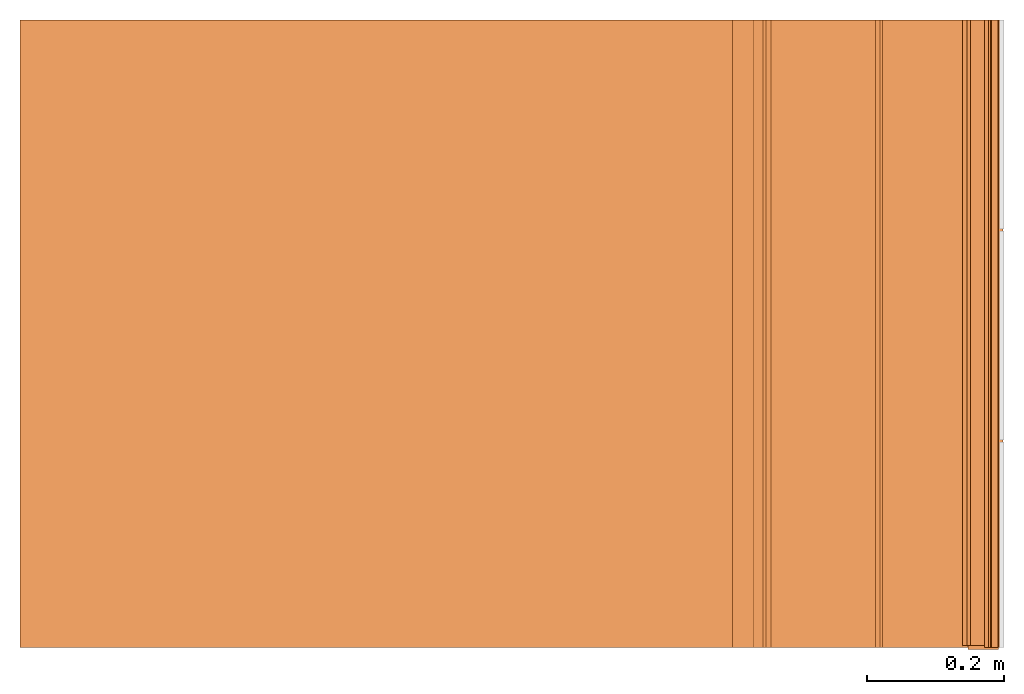
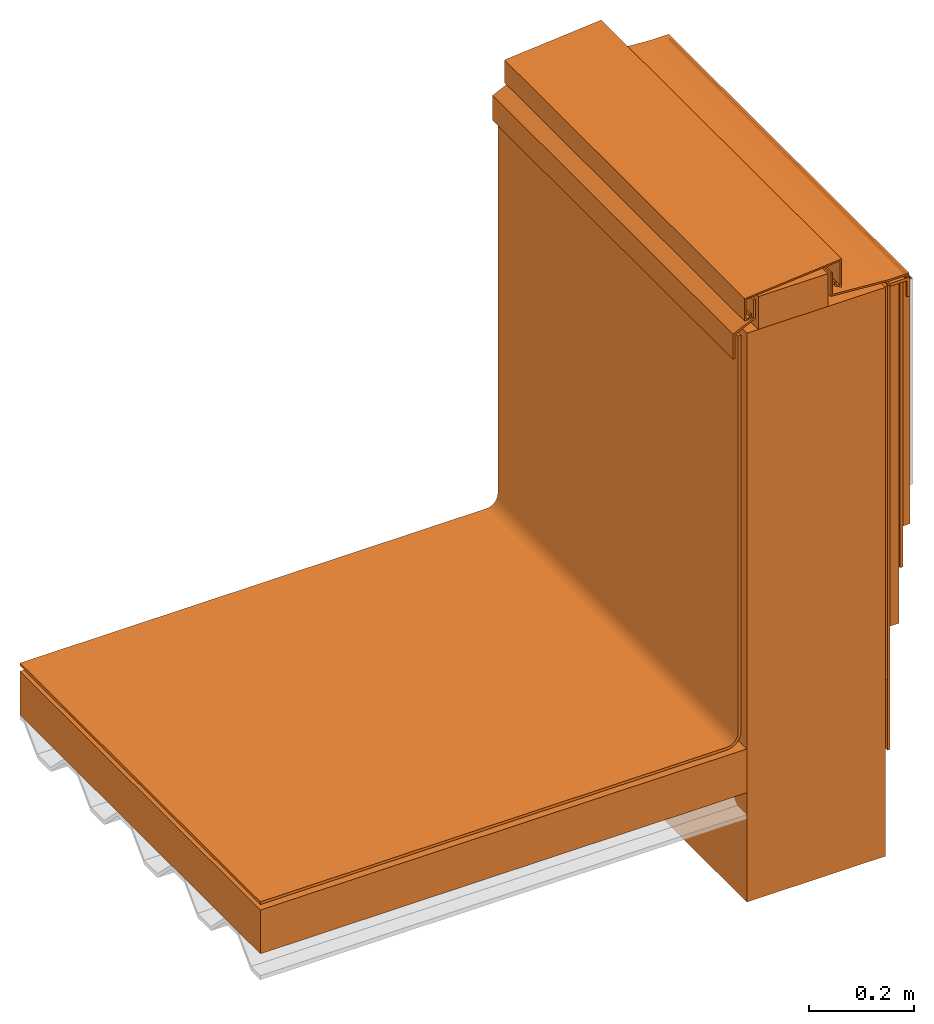
# Not in any storey, part 1 of 2: 15 proxies.
"""IFC4 building model written with IfcOpenShell, lengths in metres."""

from ifc_helpers import new_model, entity, si_unit, converted_unit, direction, frame, frame_2d, origin_with_axes, place, context, project, spatial, polyline, circle_curve, parameter, trimmed, segment, composite_curve, outline, extrude, faceted_brep, source, transform, mapped, material, element, save


model = new_model("IFC4")

# Units and contexts
model_context = context("Model", 3, precision=1e-05, world=origin_with_axes(), true_north=direction((0.0, 1.0, 0.0)))
ifc_project = project(units=[si_unit("LENGTHUNIT", "METRE"), si_unit("AREAUNIT", "SQUARE_METRE"), si_unit("VOLUMEUNIT", "CUBIC_METRE"), converted_unit("PLANEANGLEUNIT", "DEGREE", entity("IfcPlaneAngleMeasure", 0.017453292519943295), si_unit("PLANEANGLEUNIT", "RADIAN"), dimensions=[0, 0, 0, 0, 0, 0, 0])], contexts=[model_context])

# Site, building
site = spatial("IfcSite", under=ifc_project, CompositionType="ELEMENT")
building = spatial("IfcBuilding", under=site, Name="Default Building", CompositionType="ELEMENT")

# Proxies
ifc_material_1 = material(Name="Rigid insulation")
shared_shape_1 = source(origin_with_axes(), model_context, "Body", "SweptSolid", [
    extrude(outline(polyline([(-0.534154579064998, -0.0508000000000002), (0.534154579065005, -0.0508000000000002), (0.534154579065005, 0.0508000000000002), (-0.534154579064998, 0.0508000000000002), (-0.534154579064998, -0.0508000000000002)])), frame((36.407658727175, 4.6228, 0.0), z_axis=(0.0, 0.0, 1.0), x_axis=(1.0, 0.0, 0.0)), (0.0, 0.0, 1.0), 0.9144),
])
proxy_1_placement = place(None, origin_with_axes())
element("IfcBuildingElementProxy", 1, at=proxy_1_placement, inside=building, material=ifc_material_1, Name="Rigid insulation 002", PredefinedType="ELEMENT", context=model_context, shape_type="MappedRepresentation", body=[
    mapped(shared_shape_1, transform((0.663457710536, -23.9771529893, 0.0), x_axis=(1.0, 0.0, 0.0), y_axis=(0.0, 2.22044604925031e-16, 1.0), z_axis=(0.0, -1.0, 2.22044604925031e-16), scale=1.0)),
])
ifc_material_2 = material()
shared_shape_2 = source(origin_with_axes(), model_context, "Body", "SweptSolid", [
    extrude(outline(polyline([(-0.0761999999999971, -0.0381000000000004), (0.0762000000000044, -0.0381000000000004), (0.0762000000000044, 0.0380999999999995), (-0.0761999999999971, 0.0380999999999995), (-0.0761999999999971, -0.0381000000000004)])), frame((37.04341330624, 5.6769, 0.0), z_axis=(0.0, 0.0, 1.0), x_axis=(1.0, 0.0, 0.0)), (0.0, 0.0, 1.0), 0.9144),
])
proxy_2_placement = place(None, origin_with_axes())
element("IfcBuildingElementProxy", 2, at=proxy_2_placement, inside=building, material=ifc_material_2, Name="Wood block 002", PredefinedType="ELEMENT", context=model_context, shape_type="MappedRepresentation", body=[
    mapped(shared_shape_2, transform((0.663457710536, -23.9771529893, 0.0), x_axis=(1.0, 0.0, 0.0), y_axis=(0.0, 2.22044604925031e-16, 1.0), z_axis=(0.0, -1.0, 2.22044604925031e-16), scale=1.0)),
])
ifc_material_3 = material(Name="Sealant")
shared_shape_3 = source(origin_with_axes(), model_context, "Body", "SweptSolid", [
    extrude(outline(composite_curve([segment(polyline([(-0.0015163712287831, -0.00163855200248508, 0.0), (-0.0015163712287831, 0.00515275658938936, 0.0)]), True, "CONTINUOUS"), segment(polyline([(-0.0015163712287831, 0.00515275658938936, 0.0), (-0.00141551732565858, 0.00515275658751489, 0.0)]), True, "CONTINUOUS"), segment(trimmed(circle_curve(frame_2d((0.00537579127121735, 0.00515275658751513, 0.0), x_axis=(1.0, 0.0)), 0.00679130859375), [parameter(180.0)], [parameter(269.999999789081)], True, "PARAMETER"), True, "CONTINUOUS"), segment(polyline([(0.00537579124621698, -0.00163855200435955, 0.0), (-0.0015163712287831, -0.00163855200248508, 0.0)]), True, "CONTINUOUS")], self_intersect=False)), frame((37.3001054337288, 5.64043855200249, 0.0), z_axis=(0.0, 0.0, 1.0), x_axis=(1.0, 0.0, 0.0)), (0.0, 0.0, 1.0), 0.9144),
])
proxy_3_placement = place(None, origin_with_axes())
element("IfcBuildingElementProxy", 3, at=proxy_3_placement, inside=building, material=ifc_material_3, Name="Sealant 002", PredefinedType="ELEMENT", context=model_context, shape_type="MappedRepresentation", body=[
    mapped(shared_shape_3, transform((0.663457710536, -23.9771529893, 0.0), x_axis=(1.0, 0.0, 0.0), y_axis=(0.0, 2.22044604925031e-16, 1.0), z_axis=(0.0, -1.0, 2.22044604925031e-16), scale=1.0)),
])
ifc_material_4 = material(Name="L-shaped aluminium profile")
shared_shape_4 = source(origin_with_axes(), model_context, "Body", "SweptSolid", [
    extrude(outline(polyline([(-0.0306147784733839, 0.00675514340991504), (-0.0306147784733839, 0.0134701824799158), (0.0134701824266158, 0.0134701824799158), (0.0134701824266158, -0.0306147784500845), (0.0067551433266126, -0.0306147784500845), (0.0067551433266126, 0.00675514340991504), (-0.0306147784733839, 0.00675514340991504)])), frame((37.2851188800734, 5.63275608705388, 0.0), z_axis=(0.0, 0.0, 1.0), x_axis=(1.0, 0.0, 0.0)), (0.0, 0.0, 1.0), 0.91694),
])
proxy_4_placement = place(None, origin_with_axes())
element("IfcBuildingElementProxy", 4, at=proxy_4_placement, inside=building, material=ifc_material_4, Name="Aluminium profile 002", PredefinedType="ELEMENT", context=model_context, shape_type="MappedRepresentation", body=[
    mapped(shared_shape_4, transform((0.663457710536, -23.9771529893, 0.0), x_axis=(1.0, 0.0, 0.0), y_axis=(0.0, 2.22044604925031e-16, 1.0), z_axis=(0.0, -1.0, 2.22044604925031e-16), scale=1.0)),
])
ifc_material_5 = material(Name="Existing concrete wall")
shared_shape_5 = source(origin_with_axes(), model_context, "Body", "SweptSolid", [
    extrude(outline(polyline([(-0.152400000000001, -0.6604), (0.152400000000001, -0.6604), (0.152400000000001, 0.660400000000001), (-0.152400000000001, 0.660400000000001), (-0.152400000000001, -0.6604)])), frame((37.09421330624, 5.1816, 0.0), z_axis=(0.0, 0.0, 1.0), x_axis=(1.0, 0.0, 0.0)), (0.0, 0.0, 1.0), 0.9144),
])
proxy_5_placement = place(None, origin_with_axes())
element("IfcBuildingElementProxy", 5, at=proxy_5_placement, inside=building, material=ifc_material_5, Name="Concrete wall 002", PredefinedType="ELEMENT", context=model_context, shape_type="MappedRepresentation", body=[
    mapped(shared_shape_5, transform((0.663457710536, -23.9771529893, -0.2032), x_axis=(1.0, 0.0, 0.0), y_axis=(0.0, 2.22044604925031e-16, 1.0), z_axis=(0.0, -1.0, 2.22044604925031e-16), scale=1.0)),
])
ifc_material_6 = material(Name="WRB Membrane")
shared_shape_6 = source(origin_with_axes(), model_context, "Body", "SweptSolid", [
    extrude(outline(polyline([(-0.00317500003346504, -0.33134604492), (0.00317500003346504, -0.33134604492), (0.00317500003346504, 0.33134604492), (-0.00317500003346504, 0.33134604492), (-0.00317500003346504, -0.33134604492)])), frame((37.2815383062335, 5.30745395508, 0.0), z_axis=(0.0, 0.0, 1.0), x_axis=(1.0, 0.0, 0.0)), (0.0, 0.0, 1.0), 0.9144),
])
proxy_6_placement = place(None, origin_with_axes())
element("IfcBuildingElementProxy", 6, at=proxy_6_placement, inside=building, material=ifc_material_6, Name="Membrane 002", PredefinedType="ELEMENT", context=model_context, shape_type="MappedRepresentation", body=[
    mapped(shared_shape_6, transform((0.663457710536, -23.9771529893, 0.0), x_axis=(1.0, 0.0, 0.0), y_axis=(0.0, 2.22044604925031e-16, 1.0), z_axis=(0.0, -1.0, 2.22044604925031e-16), scale=1.0)),
])
ifc_material_7 = material(Name="Cement bond coat")
shared_shape_7 = source(origin_with_axes(), model_context, "Body", "SweptSolid", [
    extrude(outline(polyline([(-0.0079375, -0.28392294922), (0.0079375, -0.28392294922), (0.0079375, 0.28392294922), (-0.0079375, 0.28392294922), (-0.0079375, -0.28392294922)])), frame((37.2926508063, 5.35487705078, 0.0), z_axis=(0.0, 0.0, 1.0), x_axis=(1.0, 0.0, 0.0)), (0.0, 0.0, 1.0), 0.9144),
])
proxy_7_placement = place(None, origin_with_axes())
element("IfcBuildingElementProxy", 7, at=proxy_7_placement, inside=building, material=ifc_material_7, Name="Cement bond coat 002", PredefinedType="ELEMENT", context=model_context, shape_type="MappedRepresentation", body=[
    mapped(shared_shape_7, transform((0.663457710536, -23.9771529893, 0.0), x_axis=(1.0, 0.0, 0.0), y_axis=(0.0, 2.22044604925031e-16, 1.0), z_axis=(0.0, -1.0, 2.22044604925031e-16), scale=1.0)),
])
ifc_material_8 = material(Name="TPO Membrane")
shared_shape_8 = source(origin_with_axes(), model_context, "Body", "SweptSolid", [
    extrude(outline(composite_curve([segment(polyline([(0.275218948983449, 0.722803444895089, 0.0), (0.281568948982989, 0.722803444895089, 0.0)]), True, "CONTINUOUS"), segment(polyline([(0.281568948982989, 0.722803444895089, 0.0), (0.281568948982531, -0.197946555104912, 0.0)]), True, "CONTINUOUS"), segment(trimmed(circle_curve(frame_2d((0.249818948983375, -0.197946555104863, 0.0), x_axis=(1.0, 0.0)), 0.0317499999990796), [parameter(0.0)], [parameter(270.000000000131)], False, "PARAMETER"), True, "CONTINUOUS"), segment(polyline([(0.249818948983448, -0.229696555103991, 0.0), (-0.774040209146551, -0.229696555104451, 0.0)]), True, "CONTINUOUS"), segment(polyline([(-0.774040209146551, -0.229696555104451, 0.0), (-0.774040209146551, -0.223346555104911, 0.0)]), True, "CONTINUOUS"), segment(polyline([(-0.774040209146551, -0.223346555104911, 0.0), (0.249818948983448, -0.223346555104911, 0.0)]), True, "CONTINUOUS"), segment(trimmed(circle_curve(frame_2d((0.249818948983375, -0.197946555104863, 0.0), x_axis=(1.0, 0.0)), 0.0253999999999999), [parameter(270.000000000164)], [parameter(0.0)], True, "PARAMETER"), True, "CONTINUOUS"), segment(polyline([(0.275218948983449, -0.197946555104912, 0.0), (0.275218948983449, 0.722803444895089, 0.0)]), True, "CONTINUOUS")], self_intersect=False)), frame((36.6475443572565, 4.91599655510491, 0.0), z_axis=(0.0, 0.0, 1.0), x_axis=(1.0, 0.0, 0.0)), (0.0, 0.0, 1.0), 0.9144),
])
proxy_8_placement = place(None, origin_with_axes())
element("IfcBuildingElementProxy", 8, at=proxy_8_placement, inside=building, material=ifc_material_8, Name="TPO Membrane 002", PredefinedType="ELEMENT", context=model_context, shape_type="MappedRepresentation", body=[
    mapped(shared_shape_8, transform((0.663457710536, -23.9771529893, 0.0), x_axis=(1.0, 0.0, 0.0), y_axis=(0.0, 2.22044604925031e-16, 1.0), z_axis=(0.0, -1.0, 2.22044604925031e-16), scale=1.0)),
])
ifc_material_9 = material(Name="Scratch coat")
shared_shape_9 = source(origin_with_axes(), model_context, "Body", "SweptSolid", [
    extrude(outline(polyline([(-0.00317500000000291, 0.4572), (0.00317499999999563, 0.4572), (0.00317499999999563, -0.4572), (-0.00317500000000291, -0.4572), (-0.00317500000000291, 0.4572)])), frame((37.2497883062, 5.1816, 0.0), z_axis=(0.0, 0.0, 1.0), x_axis=(1.0, 0.0, 0.0)), (0.0, 0.0, 1.0), 0.911225),
])
proxy_9_placement = place(None, origin_with_axes())
element("IfcBuildingElementProxy", 9, at=proxy_9_placement, inside=building, material=ifc_material_9, Name="Scratch coat 002", PredefinedType="ELEMENT", context=model_context, shape_type="MappedRepresentation", body=[
    mapped(shared_shape_9, transform((0.663457710536, -23.9771529893, 0.0), x_axis=(1.0, 0.0, 0.0), y_axis=(0.0, 2.22044604925031e-16, 1.0), z_axis=(0.0, -1.0, 2.22044604925031e-16), scale=1.0)),
])
ifc_material_10 = material(Name="Counter flashing - same color as porcelain tiles")
shared_shape_10 = source(origin_with_axes(), model_context, "Body", "SweptSolid", [
    extrude(outline(polyline([(-0.0956308982593619, -0.0337403714343691), (-0.0956308982593619, -0.0435269925243683), (-0.110330116959361, -0.0456812894043687), (-0.110330116959361, 0.00644175747563168), (0.102431601740638, 0.0246834566856314), (0.102431601740638, -0.0410636136243684), (0.0871855080406385, -0.0331754300243683), (0.0871855080406385, -0.0245689847143685), (0.090513632965638, -0.0245689847143685), (0.0905136329906382, -0.0311501720714732), (0.0991034767906385, -0.0355944754007733), (0.0991034767906385, 0.0210577759298785), (-0.107001992009362, 0.00338676823940659), (-0.107001992009362, -0.0418298459288753), (-0.0989590232093615, -0.0406510797001783), (-0.0989590232343617, -0.0337403714343691), (-0.0956308982593619, -0.0337403714343691)])), frame((37.0475410544594, 5.71411488315437, 0.0), z_axis=(0.0, 0.0, 1.0), x_axis=(1.0, 0.0, 0.0)), (0.0, 0.0, 1.0), 0.9144),
])
proxy_10_placement = place(None, origin_with_axes())
element("IfcBuildingElementProxy", 10, at=proxy_10_placement, inside=building, material=ifc_material_10, Name="Counter flashing 002", PredefinedType="ELEMENT", context=model_context, shape_type="MappedRepresentation", body=[
    mapped(shared_shape_10, transform((0.663457710536, -23.9771529893, 0.0), x_axis=(1.0, 0.0, 0.0), y_axis=(0.0, 2.22044604925031e-16, 1.0), z_axis=(0.0, -1.0, 2.22044604925031e-16), scale=1.0)),
])
ifc_material_11 = material(Name="Flashing")
shared_shape_11 = source(origin_with_axes(), model_context, "Body", "SweptSolid", [
    extrude(outline(polyline([(0.0626707206018182, -0.00905590685031166), (-0.0631945056364493, 8.64975727581623e-05), (-0.0631945056263648, 0.0505531826579845), (-0.0669985020412787, 0.0505531826579845), (-0.0669985020662789, -0.00345121187014047), (0.0625327479337211, -0.0128599032801412), (0.105083529108721, -0.0128599032801412), (0.105083529108721, -0.00905590685022617), (0.0626707206018182, -0.00905590685031166)])), frame((37.1932602208163, 5.66310941500014, 0.0), z_axis=(0.0, 0.0, 1.0), x_axis=(1.0, 0.0, 0.0)), (0.0, 0.0, 1.0), 0.9144),
])
proxy_11_placement = place(None, origin_with_axes())
element("IfcBuildingElementProxy", 11, at=proxy_11_placement, inside=building, material=ifc_material_11, Name="Front flashing 002", PredefinedType="ELEMENT", context=model_context, shape_type="MappedRepresentation", body=[
    mapped(shared_shape_11, transform((0.663457710536, -23.9771529893, 0.0), x_axis=(1.0, 0.0, 0.0), y_axis=(0.0, 2.22044604925031e-16, 1.0), z_axis=(0.0, -1.0, 2.22044604925031e-16), scale=1.0)),
])
shared_shape_12 = source(origin_with_axes(), model_context, "Body", "SweptSolid", [
    extrude(outline(composite_curve([segment(trimmed(circle_curve(frame_2d((-0.00400976629316574, 0.0, 0.0), x_axis=(1.0, 0.0)), 0.00180224599999935), [parameter(90.0000000418675)], [parameter(269.999999958132)], True, "PARAMETER"), True, "CONTINUOUS"), segment(polyline([(-0.00400976629448269, -0.00180224599999929, 0.0), (0.00400976629448269, -0.00180224599999929, 0.0)]), True, "CONTINUOUS"), segment(trimmed(circle_curve(frame_2d((0.00400976629316574, 0.0, 0.0), x_axis=(1.0, 0.0)), 0.00180224599999935), [parameter(270.000000041868)], [parameter(89.9999999581325)], True, "PARAMETER"), True, "CONTINUOUS"), segment(polyline([(0.00400976629579964, 0.00180224599989742, 0.0), (-0.00400976629316574, 0.00180224599989742, 0.0)]), True, "CONTINUOUS")], self_intersect=False)), frame((37.2930761722945, 5.648172363, 0.0), z_axis=(0.0, 0.0, 1.0), x_axis=(1.0, 0.0, 0.0)), (0.0, 0.0, 1.0), 0.9144),
])
proxy_12_placement = place(None, origin_with_axes())
element("IfcBuildingElementProxy", 12, at=proxy_12_placement, inside=building, material=ifc_material_3, Name="Top sealant 002", PredefinedType="ELEMENT", context=model_context, shape_type="MappedRepresentation", body=[
    mapped(shared_shape_12, transform((0.663457710536, -23.9771529893, 0.0), x_axis=(1.0, 0.0, 0.0), y_axis=(0.0, 2.22044604925031e-16, 1.0), z_axis=(0.0, -1.0, 2.22044604925031e-16), scale=1.0)),
])
shared_shape_13 = source(origin_with_axes(), model_context, "Body", "SweptSolid", [
    extrude(outline(polyline([(-0.022590768301452, -0.0622137447992236), (-0.022590768301452, -0.00408245374901708), (0.0222568879985483, 0.0171997728109836), (0.0222568879985483, 0.0597794192607762), (0.0264404817985487, 0.0597794192607762), (0.0264404817985487, 0.0145543216007763), (-0.0184071745014517, -0.00672790495922436), (-0.0184071745014517, -0.0622137447992236), (-0.022590768301452, -0.0622137447992236)])), frame((36.9339306120015, 5.65140710417922, 0.0), z_axis=(0.0, 0.0, 1.0), x_axis=(1.0, 0.0, 0.0)), (0.0, 0.0, 1.0), 0.9144),
])
proxy_13_placement = place(None, origin_with_axes())
element("IfcBuildingElementProxy", 13, at=proxy_13_placement, inside=building, material=ifc_material_11, Name="Back flashing 002", PredefinedType="ELEMENT", context=model_context, shape_type="MappedRepresentation", body=[
    mapped(shared_shape_13, transform((0.663457710536, -23.9771529893, 0.0), x_axis=(1.0, 0.0, 0.0), y_axis=(0.0, 2.22044604925031e-16, 1.0), z_axis=(0.0, -1.0, 2.22044604925031e-16), scale=1.0)),
])
ifc_material_12 = material(Name="Metal lath")
proxy_14_placement = place(None, origin_with_axes())
element("IfcBuildingElementProxy", 14, at=proxy_14_placement, inside=building, material=ifc_material_12, Name="Metal lath 002", PredefinedType="ELEMENT", context=model_context, shape_type="Brep", body=[
    faceted_brep([(37.9214483605, -24.8883779893, 4.55940087891), (37.9164483605, -24.8883779893, 4.55940087891), (37.9164483605, -23.9771529893, 4.55940087891), (37.9214483605, -23.9771529893, 4.55940087891), (37.9214483605, -23.9771529893, 4.55940087891), (37.9164483605, -23.9771529893, 4.55940087891), (37.9164483605, -23.9771529893, 5.6388), (37.9214483605, -23.9771529893, 5.6388), (37.9214483605, -23.9771529893, 5.6388), (37.9164483605, -23.9771529893, 5.6388), (37.9164483605, -24.8883779893, 5.6388), (37.9214483605, -24.8883779893, 5.6388), (37.9214483605, -24.8883779893, 5.6388), (37.9164483605, -24.8883779893, 5.6388), (37.9164483605, -24.8883779893, 4.55940087891), (37.9214483605, -24.8883779893, 4.55940087891), (37.9214483605, -23.9771529893, 5.6388), (37.9214483605, -24.8883779893, 5.6388), (37.9214483605, -24.8883779893, 4.55940087891), (37.9214483605, -23.9771529893, 4.55940087891), (37.9164483605, -23.9771529893, 4.55940087891), (37.9164483605, -24.8883779893, 4.55940087891), (37.9164483605, -24.8883779893, 5.6388), (37.9164483605, -23.9771529893, 5.6388)], [[[0, 1, 2, 3]], [[4, 5, 6, 7]], [[8, 9, 10, 11]], [[12, 13, 14, 15]], [[16, 17, 18, 19]], [[20, 21, 22, 23]]]),
])
ifc_material_13 = material(Name="Mortar bed")
proxy_15_placement = place(None, origin_with_axes())
element("IfcBuildingElementProxy", 15, at=proxy_15_placement, inside=building, material=ifc_material_13, Name="Mortar bed 002", PredefinedType="ELEMENT", context=model_context, shape_type="Brep", body=[
    faceted_brep([(37.941821016736, -24.8883779893, 4.84604150391), (37.921421016736, -24.8883779893, 4.84604150391), (37.921421016736, -23.9771529893, 4.84604150391), (37.941821016736, -23.9771529893, 4.84604150391), (37.941821016736, -23.9771529893, 5.6388), (37.921421016736, -23.9771529893, 5.6388), (37.921421016736, -24.8883779893, 5.6388), (37.941821016736, -24.8883779893, 5.6388), (37.941821016736, -23.9771529893, 4.84604150391), (37.921421016736, -23.9771529893, 4.84604150391), (37.921421016736, -23.9771529893, 5.6388), (37.941821016736, -23.9771529893, 5.6388), (37.941821016736, -24.8883779893, 5.6388), (37.921421016736, -24.8883779893, 5.6388), (37.921421016736, -24.8883779893, 4.84604150391), (37.941821016736, -24.8883779893, 4.84604150391), (37.941821016736, -23.9771529893, 5.6388), (37.941821016736, -24.8883779893, 5.6388), (37.941821016736, -24.8883779893, 4.84604150391), (37.941821016736, -23.9771529893, 4.84604150391), (37.921421016736, -23.9771529893, 4.84604150391), (37.921421016736, -24.8883779893, 4.84604150391), (37.921421016736, -24.8883779893, 5.6388), (37.921421016736, -23.9771529893, 5.6388)], [[[0, 1, 2, 3]], [[4, 5, 6, 7]], [[8, 9, 10, 11]], [[12, 13, 14, 15]], [[16, 17, 18, 19]], [[20, 21, 22, 23]]]),
])

save(model, "model.ifc")
